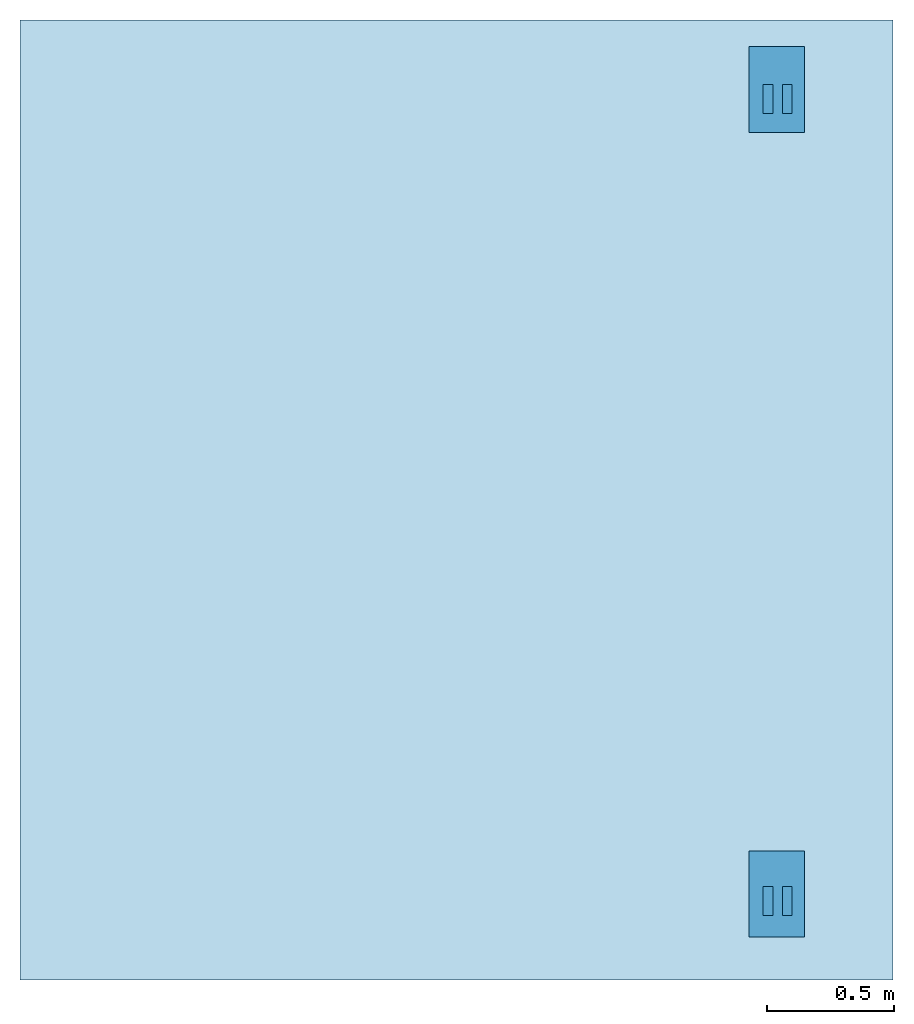
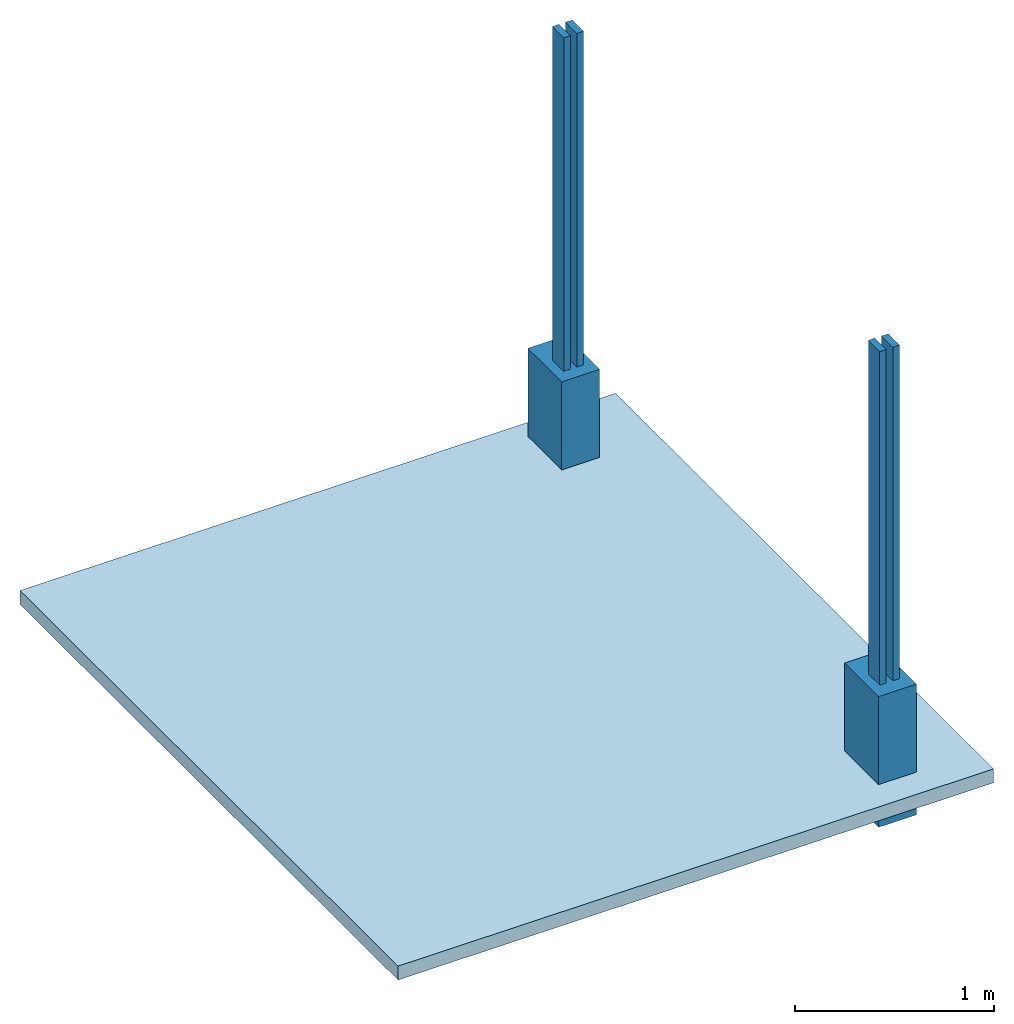
"""IFC4X3_ADD2 building model written with IfcOpenShell, lengths in millimetres."""

from ifc_helpers import new_model, entity, si_unit, converted_unit, direction, frame, origin_with_axes, origin_2d_with_axis, place, context, subcontext, project, spatial, indexed_curve, rectangle, outline, extrude, material, layer, layer_set, layer_usage, material_profile, profile_set, profile_usage, type_object, element, save


model = new_model("IFC4X3_ADD2")

# Units and contexts
model_context = context("Model", 3, precision=1e-05, world=origin_with_axes(), true_north=direction((0.0, 1.0, 0.0)))
plan_context = context("Plan", 2, precision=1e-05, world=origin_2d_with_axis(), true_north=direction((0.0, 1.0)))
body_context = subcontext(model_context, "Body", "Model", "MODEL_VIEW")
ifc_project = project(units=[si_unit("AREAUNIT", "SQUARE_METRE"), si_unit("VOLUMEUNIT", "CUBIC_METRE"), si_unit("LENGTHUNIT", "METRE", prefix="MILLI"), converted_unit("PLANEANGLEUNIT", "degree", entity("IfcReal", 0.0174532925199433), si_unit("PLANEANGLEUNIT", "RADIAN"), dimensions=[0, 0, 0, 0, 0, 0, 0])], contexts=[model_context, plan_context])

# Site, building, storeys
site_placement = place(None, origin_with_axes())
site = spatial("IfcSite", under=ifc_project, at=site_placement)
building_placement = place(site_placement, origin_with_axes())
building = spatial("IfcBuilding", under=site, at=building_placement, Name="Simple 1Bed House")
storey_1_placement = place(building_placement, origin_with_axes())
storey_1 = spatial("IfcBuildingStorey", under=building, at=storey_1_placement, Name="Outside")
storey_2_placement = place(storey_1_placement, frame((0.0, 0.0, 1.00000004749745), z_axis=(0.0, 0.0, 1.0), x_axis=(1.0, 0.0, 0.0)))
storey_2 = spatial("IfcBuildingStorey", under=storey_1, at=storey_2_placement, Name="Balcony")

# Beams
ifc_material_1 = material(Name="Timber pine", Category="Wood")
ifc_material_profile = material_profile(ifc_material_1, rectangle(XDim=38.0, YDim=114.0))
ifc_profile_set = profile_set([ifc_material_profile], Name="timber-material")
ifc_profile_usage_1 = profile_usage(ifc_profile_set, cardinal=5)
beam_type = type_object("IfcBeamType", Name="Timber 38x114", PredefinedType="BEAM", material=ifc_profile_set)
beam_1_placement = place(storey_2_placement, frame((11406.005859375, 3511.31892204285, 449.000137043186), z_axis=(1.50995774106374e-07, -1.19209289550779e-07, 0.999999999999982), x_axis=(-0.999999999999977, 1.50995802528083e-07, 1.50995788317228e-07)))
element("IfcBeam", 1, at=beam_1_placement, inside=storey_2, type_object=beam_type, material=ifc_profile_usage_1, PredefinedType="BEAM", context=body_context, shape_type="SweptSolid", body=[
    extrude(rectangle(XDim=38.0, YDim=114.0), origin_with_axes(), (0.0, 0.0, 1.0), 2044.93924691934),
])
ifc_profile_usage_2 = profile_usage(ifc_profile_set, cardinal=5)
beam_2_placement = place(storey_2_placement, frame((11330.005645752, 3511.31892204285, 449.000137043186), z_axis=(1.50995774106374e-07, -1.19209289550779e-07, 0.999999999999982), x_axis=(-0.999999999999977, 1.50995802528083e-07, 1.50995788317228e-07)))
element("IfcBeam", 2, at=beam_2_placement, inside=storey_2, type_object=beam_type, material=ifc_profile_usage_2, PredefinedType="BEAM", context=body_context, shape_type="SweptSolid", body=[
    extrude(rectangle(XDim=38.0, YDim=114.0), origin_with_axes(), (0.0, 0.0, 1.0), 2044.9390137402),
])
ifc_profile_usage_3 = profile_usage(ifc_profile_set, cardinal=5)
beam_3_placement = place(storey_2_placement, frame((11330.005645752, 342.442274093628, 449.000137043186), z_axis=(1.50995774106374e-07, -1.19209289550779e-07, 0.999999999999982), x_axis=(-0.999999999999977, 1.50995802528083e-07, 1.50995788317228e-07)))
element("IfcBeam", 3, at=beam_3_placement, inside=storey_2, type_object=beam_type, material=ifc_profile_usage_3, Name="Timber-38x114x2000", PredefinedType="BEAM", context=body_context, shape_type="SweptSolid", body=[
    extrude(rectangle(XDim=38.0, YDim=114.0), origin_with_axes(), (0.0, 0.0, 1.0), 2044.9390137402),
])
ifc_profile_usage_4 = profile_usage(ifc_profile_set, cardinal=5)
beam_4_placement = place(storey_2_placement, frame((11406.005859375, 342.442274093628, 449.000137043186), z_axis=(1.50995774106374e-07, -1.19209289550779e-07, 0.999999999999982), x_axis=(-0.999999999999977, 1.50995802528083e-07, 1.50995788317228e-07)))
element("IfcBeam", 4, at=beam_4_placement, inside=storey_2, type_object=beam_type, material=ifc_profile_usage_4, PredefinedType="BEAM", context=body_context, shape_type="SweptSolid", body=[
    extrude(rectangle(XDim=38.0, YDim=114.0), origin_with_axes(), (0.0, 0.0, 1.0), 2044.93924691934),
])

# Slab
ifc_material_2 = material(Name="25 MPa wooden float", Category="Concrete")
ifc_layer_1 = layer(ifc_material_2, 85.0)
ifc_layer_set_1 = layer_set([ifc_layer_1], Name="concrete")
ifc_layer_usage_1 = layer_usage(ifc_layer_set_1, "AXIS3", "POSITIVE", 0.0)
slab_type = type_object("IfcSlabType", Name="85mm surface bed", PredefinedType="BASESLAB", material=ifc_layer_set_1)
slab_placement = place(storey_2_placement, frame((8375.00858306885, 3534.76762771606, -170.999942230992), z_axis=(0.0, 0.0, 1.0), x_axis=(0.999999999999993, 1.1920928955078e-07, 0.0)))
element("IfcSlab", 5, at=slab_placement, inside=storey_2, type_object=slab_type, material=ifc_layer_usage_1, Name="Slab", context=body_context, shape_type="SweptSolid", body=[
    extrude(outline(indexed_curve([(3448.66381835938, 288.551177978516), (3448.66381835938, -3503.76684570312), (0.0, -3503.76684570312), (0.0, 288.551177978516), (3448.66381835938, 288.551177978516)])), None, (0.0, 0.0, 1.0), 85.0),
])

# Walls
ifc_material_3 = material(Name="FNP-Red", Category="Clay Bricks")
ifc_layer_2 = layer(ifc_material_3, 220.0, Name="hg")
ifc_layer_set_2 = layer_set([ifc_layer_2], Name="brick")
ifc_layer_usage_2 = layer_usage(ifc_layer_set_2, "AXIS2", "POSITIVE", 0.0)
wall_type = type_object("IfcWallType", Name="220mm load bearing", PredefinedType="SOLIDWALL", material=ifc_layer_set_2)
wall_1_placement = place(storey_2_placement, frame((11475.0061035156, 3378.13019752502, -347.634358215146), z_axis=(0.0, 0.0, 1.0), x_axis=(1.94707183709394e-07, 0.999999999999981, 0.0)))
element("IfcWall", 6, at=wall_1_placement, inside=storey_2, type_object=wall_type, material=ifc_layer_usage_2, Name="Wall", context=body_context, shape_type="SweptSolid", body=[
    extrude(outline(indexed_curve([(0.0, 0.0), (0.0, 220.0), (340.00014948491, 220.0), (340.00014948491, 0.0), (0.0, 0.0)], self_intersect=False)), origin_with_axes(), (0.0, 0.0, 1.0), 800.000011920929),
])
ifc_layer_usage_3 = layer_usage(ifc_layer_set_2, "AXIS2", "POSITIVE", 0.0)
wall_2_placement = place(storey_2_placement, frame((11475.0061035156, 200.847133994102, -347.634358215146), z_axis=(0.0, 0.0, 1.0), x_axis=(1.94707183709394e-07, 0.999999999999981, 0.0)))
element("IfcWall", 7, at=wall_2_placement, inside=storey_2, type_object=wall_type, material=ifc_layer_usage_3, Name="Wall", context=body_context, shape_type="SweptSolid", body=[
    extrude(outline(indexed_curve([(0.0, 0.0), (0.0, 220.0), (340.00014948491, 220.0), (340.00014948491, 0.0), (0.0, 0.0)], self_intersect=False)), origin_with_axes(), (0.0, 0.0, 1.0), 800.000011920929),
])

save(model, "model.ifc")
